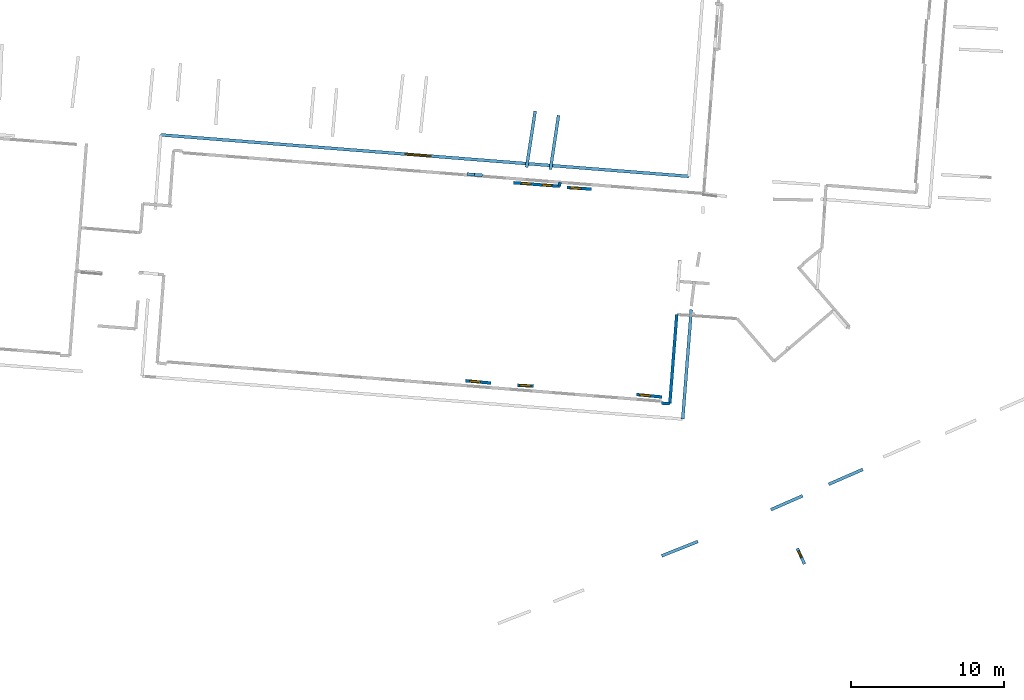
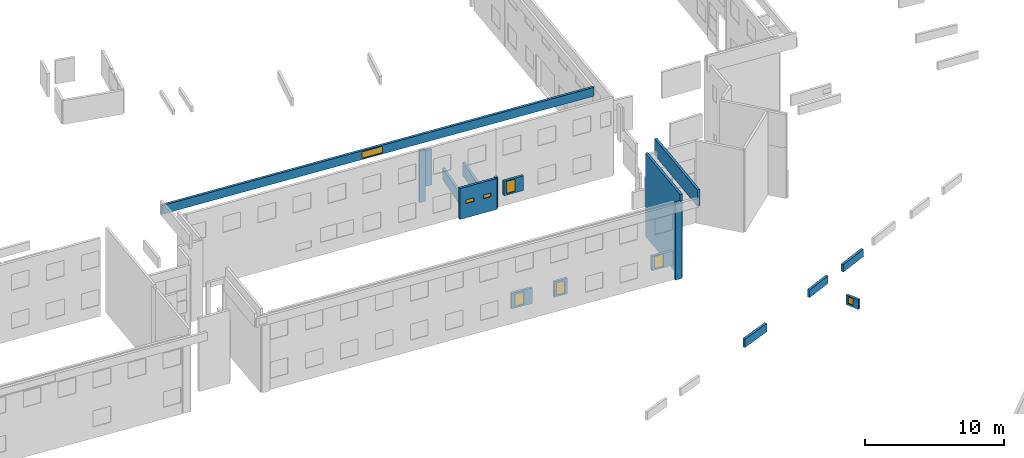
# One storey, part 19 of 27: 18 walls, 8 windows, 8 openings.
"""IFC2X3 building model written with IfcOpenShell, lengths in metres."""

from ifc_helpers import new_model, entity, si_unit, converted_unit, derived_unit, direction, frame, frame_2d, origin, origin_2d_with_axis, place, context, subcontext, project, spatial, polyline, rectangle, outline, extrude, source, transform, mapped, material, layer, layer_set, layer_usage, type_object, type_shapes, element, fill, save


model = new_model("IFC2X3")

# Units and contexts
model_context = context("Model", 3, precision=1e-05, world=origin(), true_north=direction((0.0, 1.0)))
body_context = subcontext(model_context, "Body", "Model", "MODEL_VIEW")
ifc_project = project(units=[si_unit("LENGTHUNIT", "METRE"), si_unit("AREAUNIT", "SQUARE_METRE"), si_unit("VOLUMEUNIT", "CUBIC_METRE"), converted_unit("PLANEANGLEUNIT", "DEGREE", entity("IfcRatioMeasure", 0.0174532925199433), si_unit("PLANEANGLEUNIT", "RADIAN"), dimensions=[0, 0, 0, 0, 0, 0, 0]), si_unit("MASSUNIT", "GRAM", prefix="KILO"), derived_unit("MASSDENSITYUNIT", [(si_unit("MASSUNIT", "GRAM", prefix="KILO"), 1), (si_unit("LENGTHUNIT", "METRE"), -3)]), derived_unit("MOMENTOFINERTIAUNIT", [(si_unit("LENGTHUNIT", "METRE"), 4)]), si_unit("TIMEUNIT", "SECOND"), si_unit("FREQUENCYUNIT", "HERTZ"), si_unit("THERMODYNAMICTEMPERATUREUNIT", "DEGREE_CELSIUS"), derived_unit("THERMALTRANSMITTANCEUNIT", [(si_unit("MASSUNIT", "GRAM", prefix="KILO"), 1), (si_unit("THERMODYNAMICTEMPERATUREUNIT", "KELVIN"), -1), (si_unit("TIMEUNIT", "SECOND"), -3)]), derived_unit("VOLUMETRICFLOWRATEUNIT", [(si_unit("LENGTHUNIT", "METRE"), 3), (si_unit("TIMEUNIT", "SECOND"), -1)]), si_unit("ELECTRICCURRENTUNIT", "AMPERE"), si_unit("ELECTRICVOLTAGEUNIT", "VOLT"), si_unit("POWERUNIT", "WATT"), si_unit("FORCEUNIT", "NEWTON", prefix="KILO"), si_unit("ILLUMINANCEUNIT", "LUX"), si_unit("LUMINOUSFLUXUNIT", "LUMEN"), si_unit("LUMINOUSINTENSITYUNIT", "CANDELA"), derived_unit("USERDEFINED", [(si_unit("MASSUNIT", "GRAM", prefix="KILO"), -1), (si_unit("LENGTHUNIT", "METRE"), -2), (si_unit("TIMEUNIT", "SECOND"), 3), (si_unit("LUMINOUSFLUXUNIT", "LUMEN"), 1)]), derived_unit("LINEARVELOCITYUNIT", [(si_unit("LENGTHUNIT", "METRE"), 1), (si_unit("TIMEUNIT", "SECOND"), -1)]), si_unit("PRESSUREUNIT", "PASCAL"), derived_unit("USERDEFINED", [(si_unit("LENGTHUNIT", "METRE"), -2), (si_unit("MASSUNIT", "GRAM", prefix="KILO"), 1), (si_unit("TIMEUNIT", "SECOND"), -2)]), derived_unit("LINEARFORCEUNIT", [(si_unit("MASSUNIT", "GRAM", prefix="KILO"), 1), (si_unit("LENGTHUNIT", "METRE"), 1), (si_unit("TIMEUNIT", "SECOND"), -2), (si_unit("LENGTHUNIT", "METRE"), -1)]), derived_unit("PLANARFORCEUNIT", [(si_unit("MASSUNIT", "GRAM", prefix="KILO"), 1), (si_unit("LENGTHUNIT", "METRE"), 1), (si_unit("TIMEUNIT", "SECOND"), -2), (si_unit("LENGTHUNIT", "METRE"), -2)])], contexts=[model_context])

# Site, building, storey
placement_1 = place(None, origin())
site = spatial("IfcSite", under=ifc_project, at=placement_1, CompositionType="ELEMENT")
building = spatial("IfcBuilding", under=site, at=placement_1, CompositionType="ELEMENT")
storey_placement = place(placement_1, frame((0.0, 0.0, -61.043098449707)))
storey = spatial("IfcBuildingStorey", under=building, at=storey_placement, Name="level_-61.043098", CompositionType="ELEMENT", Elevation=-61.043098449707)

# Wall
ifc_material_1 = material(Name="Default wall")
ifc_layer = layer(ifc_material_1, 0.2)
ifc_layer_set = layer_set([ifc_layer], Name="wall_thickness_0.2000")
ifc_layer_usage = layer_usage(ifc_layer_set, "AXIS2", "POSITIVE", -0.1)
wall_type = type_object("IfcWallType", Name="wall_thickness_0.2000", PredefinedType="STANDARD", material=ifc_layer_set)
placement_2 = place(placement_1, frame((0.0, 0.0, -60.9578857421875)))
wall_1_placement = place(placement_2, frame((12.4977037175095, -24.4355774544078, 0.0), z_axis=(0.0, 0.0, 1.0), x_axis=(0.916577001729123, 0.399858224751288, 0.0)))
element("IfcWallStandardCase", 1, at=wall_1_placement, inside=storey, type_object=wall_type, material=ifc_layer_usage, Name="Wall:188", ObjectType="Wall", context=body_context, shape_type="SweptSolid", body=[
    extrude(outline(polyline([(2.42807140887, -0.1), (2.42807140887, 0.1), (0.0, 0.1), (0.0, -0.1), (2.42807140887, -0.1)])), origin(), (0.0, 0.0, 1.0), 0.661750793457031),
])

# Wall, opening, window
placement_3 = place(placement_1, frame((0.0, 0.0, -59.9867630004883)))
wall_2_placement = place(placement_3, frame((-9.53913135897967, -17.8325300511373, 0.0), z_axis=(0.0, 0.0, 1.0), x_axis=(-0.995607049525731, 0.0936301390294245, 0.0)))
wall_2 = element("IfcWallStandardCase", 2, at=wall_2_placement, inside=storey, type_object=wall_type, material=ifc_layer_usage, Name="Wall:257", ObjectType="Wall", context=body_context, shape_type="SweptSolid", body=[
    extrude(outline(polyline([(1.66415564610827, -0.1), (1.66415564610827, 0.1), (0.0, 0.1), (0.0, -0.1), (1.66415564610827, -0.1)])), origin(), (0.0, 0.0, 1.0), 1.37465286254883),
])
opening_1_placement = place(wall_2_placement, frame((0.693317166831957, -0.1, 0.15277099609375)))
opening_1 = element("IfcOpeningElement", 3, at=opening_1_placement, cuts=wall_2, Name="Opening : 690 x 1070 : 15", ObjectType="Opening", context=body_context, shape_type="SweptSolid", body=[
    extrude(rectangle(XDim=0.69, YDim=1.07, at=frame_2d((0.535, 0.345), x_axis=(0.0, 1.0))), frame((0.0, 0.0, 0.0), z_axis=(0.0, 1.0, 0.0), x_axis=(0.0, 0.0, 1.0)), (0.0, 0.0, 1.0), 0.2),
])
ifc_material_2 = material(Name="Window Default")
window_style_1 = type_object("IfcWindowStyle", Name="Window : 690 x 1070mm", ConstructionType="NOTDEFINED", OperationType="NOTDEFINED", ParameterTakesPrecedence=False, Sizeable=False, material=ifc_material_2)
shared_shape_1 = source(origin(), body_context, "Body", "SweptSolid", [
    extrude(rectangle(XDim=0.1, YDim=0.69, at=origin_2d_with_axis()), frame((0.345, 0.1, 0.0), z_axis=(0.0, 0.0, 1.0), x_axis=(0.0, 1.0, 0.0)), (0.0, 0.0, 1.0), 1.07),
])
type_shapes(window_style_1, [shared_shape_1])
window_1_placement = place(opening_1_placement, origin())
window_1 = element("IfcWindow", 4, at=window_1_placement, inside=storey, type_object=window_style_1, Name="Window : 690 x 1070mm : 13", ObjectType="Window : 690 x 1070mm", OverallHeight=1.07, OverallWidth=0.69, context=body_context, shape_type="MappedRepresentation", body=[
    mapped(shared_shape_1, transform((0.0, 0.0, 0.0), scale=1.0)),
])
fill(opening_1, window_1)

placement_4 = place(placement_1, frame((0.0, 0.0, -54.4207000732422)))
wall_3_placement = place(placement_4, frame((-31.0850317500552, -1.63894712927607, 0.0), z_axis=(0.0, 0.0, 1.0), x_axis=(0.996931791597171, -0.0782751742435238, 0.0)))
wall_3 = element("IfcWallStandardCase", 5, at=wall_3_placement, inside=storey, type_object=wall_type, material=ifc_layer_usage, Name="Wall:455", ObjectType="Wall", context=body_context, shape_type="SweptSolid", body=[
    extrude(outline(polyline([(34.5646927329305, -0.1), (34.5646927329305, 0.1), (0.0, 0.1), (0.0, -0.1), (34.5646927329305, -0.1)])), origin(), (0.0, 0.0, 1.0), 0.772296905517578),
])
opening_2_placement = place(wall_3_placement, frame((16.0085291385398, -0.1, 0.0967292785644531)))
opening_2 = element("IfcOpeningElement", 6, at=opening_2_placement, cuts=wall_3, Name="Opening : 1655 x 585 : 37", ObjectType="Opening", context=body_context, shape_type="SweptSolid", body=[
    extrude(rectangle(XDim=1.655, YDim=0.585, at=frame_2d((0.2925, 0.8275), x_axis=(0.0, 1.0))), frame((0.0, 0.0, 0.0), z_axis=(0.0, 1.0, 0.0), x_axis=(0.0, 0.0, 1.0)), (0.0, 0.0, 1.0), 0.2),
])
window_style_2 = type_object("IfcWindowStyle", Name="Window : 1655 x 585mm", ConstructionType="NOTDEFINED", OperationType="NOTDEFINED", ParameterTakesPrecedence=False, Sizeable=False, material=ifc_material_2)
shared_shape_2 = source(origin(), body_context, "Body", "SweptSolid", [
    extrude(rectangle(XDim=0.1, YDim=1.655, at=origin_2d_with_axis()), frame((0.8275, 0.1, 0.0), z_axis=(0.0, 0.0, 1.0), x_axis=(0.0, 1.0, 0.0)), (0.0, 0.0, 1.0), 0.585),
])
type_shapes(window_style_2, [shared_shape_2])
window_2_placement = place(opening_2_placement, origin())
window_2 = element("IfcWindow", 7, at=window_2_placement, inside=storey, type_object=window_style_2, Name="Window : 1655 x 585mm : 32", ObjectType="Window : 1655 x 585mm", OverallHeight=0.585, OverallWidth=1.655, context=body_context, shape_type="MappedRepresentation", body=[
    mapped(shared_shape_2, transform((0.0, 0.0, 0.0), scale=1.0)),
])
fill(opening_2, window_2)

# Walls
wall_4_placement = place(storey_placement, frame((-5.03805124397359, -4.72673401802016, 0.0), z_axis=(0.0, 0.0, 1.0), x_axis=(-0.129665213204993, -0.991557831134676, 0.0)))
element("IfcWallStandardCase", 8, at=wall_4_placement, inside=storey, type_object=wall_type, material=ifc_layer_usage, Name="Wall:480", ObjectType="Wall", context=body_context, shape_type="SweptSolid", body=[
    extrude(outline(polyline([(0.264290876779452, -0.1), (0.264290876779452, 0.1), (0.0, 0.1), (0.0, -0.1), (0.264290876779452, -0.1)])), origin(), (0.0, 0.0, 1.0), 2.72571182250977),
])
wall_5_placement = place(storey_placement, frame((2.58508048580188, -13.3566288035717, 0.0), z_axis=(0.0, 0.0, 1.0), x_axis=(-0.0778159706804258, -0.996967740053339, 0.0)))
element("IfcWallStandardCase", 9, at=wall_5_placement, inside=storey, type_object=wall_type, material=ifc_layer_usage, Name="Wall:677", ObjectType="Wall", context=body_context, shape_type="SweptSolid", body=[
    extrude(outline(polyline([(5.83412161884098, -0.1), (5.83412161884098, 0.1), (0.0, 0.1), (0.0, -0.1), (5.83412161884098, -0.1)])), origin(), (0.0, 0.0, 1.0), 7.32660675048828),
])
placement_5 = place(placement_1, frame((0.0, 0.0, -60.8847198486328)))
wall_6_placement = place(placement_5, frame((-5.65662918235476, -3.8956626353485, 0.0), z_axis=(0.0, 0.0, 1.0), x_axis=(0.147887768183979, 0.989004149648302, 0.0)))
element("IfcWallStandardCase", 10, at=wall_6_placement, inside=storey, type_object=wall_type, material=ifc_layer_usage, Name="Wall:711", ObjectType="Wall", context=body_context, shape_type="SweptSolid", body=[
    extrude(outline(polyline([(3.57000009706302, -0.1), (3.57000009706302, 0.1), (0.0, 0.1), (0.0, -0.1), (3.57000009706302, -0.1)])), origin(), (0.0, 0.0, 1.0), 1.1801872253418),
])

# Wall, opening, window
placement_6 = place(placement_1, frame((0.0, 0.0, -59.9867630004883)))
wall_7_placement = place(placement_6, frame((-7.81663886912711, -17.970377953164, 0.0), z_axis=(0.0, 0.0, 1.0), x_axis=(0.998124807269346, -0.0612116746505977, 0.0)))
wall_7 = element("IfcWallStandardCase", 11, at=wall_7_placement, inside=storey, type_object=wall_type, material=ifc_layer_usage, Name="Wall:952", ObjectType="Wall", context=body_context, shape_type="SweptSolid", body=[
    extrude(outline(polyline([(1.06900211306765, -0.1), (1.06900211306765, 0.1), (0.0, 0.1), (0.0, -0.1), (1.06900211306765, -0.1)])), origin(), (0.0, 0.0, 1.0), 1.37465286254883),
])
opening_3_placement = place(wall_7_placement, frame((0.164999801310482, -0.1, 0.145214080810547)))
opening_3 = element("IfcOpeningElement", 12, at=opening_3_placement, cuts=wall_7, Name="Opening : 700 x 1070 : 110", ObjectType="Opening", context=body_context, shape_type="SweptSolid", body=[
    extrude(rectangle(XDim=0.7, YDim=1.07, at=frame_2d((0.535, 0.35), x_axis=(0.0, 1.0))), frame((0.0, 0.0, 0.0), z_axis=(0.0, 1.0, 0.0), x_axis=(0.0, 0.0, 1.0)), (0.0, 0.0, 1.0), 0.2),
])
window_style_3 = type_object("IfcWindowStyle", Name="Window : 700 x 1070mm", ConstructionType="NOTDEFINED", OperationType="NOTDEFINED", ParameterTakesPrecedence=False, Sizeable=False, material=ifc_material_2)
shared_shape_3 = source(origin(), body_context, "Body", "SweptSolid", [
    extrude(rectangle(XDim=0.1, YDim=0.7, at=origin_2d_with_axis()), frame((0.35, 0.1, 0.0), z_axis=(0.0, 0.0, 1.0), x_axis=(0.0, 1.0, 0.0)), (0.0, 0.0, 1.0), 1.07),
])
type_shapes(window_style_3, [shared_shape_3])
window_3_placement = place(opening_3_placement, origin())
window_3 = element("IfcWindow", 13, at=window_3_placement, inside=storey, type_object=window_style_3, Name="Window : 700 x 1070mm : 98", ObjectType="Window : 700 x 1070mm", OverallHeight=1.07, OverallWidth=0.7, context=body_context, shape_type="MappedRepresentation", body=[
    mapped(shared_shape_3, transform((0.0, 0.0, 0.0), scale=1.0)),
])
fill(opening_3, window_3)

# Wall
placement_7 = place(placement_1, frame((0.0, 0.0, -60.8847198486328)))
wall_8_placement = place(placement_7, frame((-7.21205877372114, -3.75820354474582, 0.0), z_axis=(0.0, 0.0, 1.0), x_axis=(0.150626064042175, 0.988590809602822, 0.0)))
element("IfcWallStandardCase", 14, at=wall_8_placement, inside=storey, type_object=wall_type, material=ifc_layer_usage, Name="Wall:1071", ObjectType="Wall", context=body_context, shape_type="SweptSolid", body=[
    extrude(outline(polyline([(3.72000001448494, -0.1), (3.72000001448494, 0.1), (0.0, 0.1), (0.0, -0.1), (3.72000001448494, -0.1)])), origin(), (0.0, 0.0, 1.0), 1.01820373535156),
])

# Wall, opening, window
placement_8 = place(placement_1, frame((0.0, 0.0, -59.9867630004883)))
wall_9_placement = place(placement_8, frame((1.6137878881182, -18.7391027157031, 0.0), z_axis=(0.0, 0.0, 1.0), x_axis=(-0.99539400204523, 0.0958685594571029, 0.0)))
wall_9 = element("IfcWallStandardCase", 15, at=wall_9_placement, inside=storey, type_object=wall_type, material=ifc_layer_usage, Name="Wall:1177", ObjectType="Wall", context=body_context, shape_type="SweptSolid", body=[
    extrude(outline(polyline([(1.65842546175415, -0.1), (1.65842546175415, 0.1), (0.0, 0.1), (0.0, -0.1), (1.65842546175415, -0.1)])), origin(), (0.0, 0.0, 1.0), 1.27852630615234),
])
opening_4_placement = place(wall_9_placement, frame((0.750615696213164, -0.1, 0.132789611816406)))
opening_4 = element("IfcOpeningElement", 16, at=opening_4_placement, cuts=wall_9, Name="Opening : 695 x 1075 : 164", ObjectType="Opening", context=body_context, shape_type="SweptSolid", body=[
    extrude(rectangle(XDim=0.695, YDim=1.075, at=frame_2d((0.5375, 0.3475), x_axis=(0.0, 1.0))), frame((0.0, 0.0, 0.0), z_axis=(0.0, 1.0, 0.0), x_axis=(0.0, 0.0, 1.0)), (0.0, 0.0, 1.0), 0.2),
])
window_style_4 = type_object("IfcWindowStyle", Name="Window : 695 x 1075mm", ConstructionType="NOTDEFINED", OperationType="NOTDEFINED", ParameterTakesPrecedence=False, Sizeable=False, material=ifc_material_2)
shared_shape_4 = source(origin(), body_context, "Body", "SweptSolid", [
    extrude(rectangle(XDim=0.1, YDim=0.695, at=origin_2d_with_axis()), frame((0.3475, 0.1, 0.0), z_axis=(0.0, 0.0, 1.0), x_axis=(0.0, 1.0, 0.0)), (0.0, 0.0, 1.0), 1.075),
])
type_shapes(window_style_4, [shared_shape_4])
window_4_placement = place(opening_4_placement, origin())
window_4 = element("IfcWindow", 17, at=window_4_placement, inside=storey, type_object=window_style_4, Name="Window : 695 x 1075mm : 149", ObjectType="Window : 695 x 1075mm", OverallHeight=1.075, OverallWidth=0.695, context=body_context, shape_type="MappedRepresentation", body=[
    mapped(shared_shape_4, transform((0.0, 0.0, 0.0), scale=1.0)),
])
fill(opening_4, window_4)

# Walls
placement_9 = place(placement_1, frame((0.0, 0.0, -60.8847198486328)))
wall_10_placement = place(placement_9, frame((8.72074236151945, -26.0940565617844, 0.0), z_axis=(0.0, 0.0, 1.0), x_axis=(0.916189457370173, 0.40074540322223, 0.0)))
element("IfcWallStandardCase", 18, at=wall_10_placement, inside=storey, type_object=wall_type, material=ifc_layer_usage, Name="Wall:1522", ObjectType="Wall", context=body_context, shape_type="SweptSolid", body=[
    extrude(outline(polyline([(2.26469965870573, -0.1), (2.26469965870573, 0.1), (0.0, 0.1), (0.0, -0.1), (2.26469965870573, -0.1)])), origin(), (0.0, 0.0, 1.0), 0.666728973388672),
])
placement_10 = place(placement_1, frame((0.0, 0.0, -60.9578857421875)))
wall_11_placement = place(placement_10, frame((1.59733462857245, -29.1065291744062, 0.0), z_axis=(0.0, 0.0, 1.0), x_axis=(0.929661318041133, 0.368415300629634, 0.0)))
element("IfcWallStandardCase", 19, at=wall_11_placement, inside=storey, type_object=wall_type, material=ifc_layer_usage, Name="Wall:1611", ObjectType="Wall", context=body_context, shape_type="SweptSolid", body=[
    extrude(outline(polyline([(2.54288610821355, -0.1), (2.54288610821355, 0.1), (0.0, 0.1), (0.0, -0.1), (2.54288610821355, -0.1)])), origin(), (0.0, 0.0, 1.0), 0.739894866943359),
])

# Wall, openings, windows
wall_12_placement = place(storey_placement, frame((-5.07232000501293, -4.98879334553879, 0.0), z_axis=(0.0, 0.0, 1.0), x_axis=(-0.997094837058065, 0.0761701116721751, 0.0)))
wall_12 = element("IfcWallStandardCase", 20, at=wall_12_placement, inside=storey, type_object=wall_type, material=ifc_layer_usage, Name="Wall:1614", ObjectType="Wall", context=body_context, shape_type="SweptSolid", body=[
    extrude(outline(polyline([(2.99449164619464, -0.1), (2.99449164619464, 0.1), (0.0, 0.1), (0.0, -0.1), (2.99449164619464, -0.1)])), origin(), (0.0, 0.0, 1.0), 2.72571182250977),
])
opening_5_placement = place(wall_12_placement, frame((0.511039999586011, -0.1, 1.2650260925293)))
opening_5 = element("IfcOpeningElement", 21, at=opening_5_placement, cuts=wall_12, Name="Opening : 605 x 320 : 266", ObjectType="Opening", context=body_context, shape_type="SweptSolid", body=[
    extrude(rectangle(XDim=0.605, YDim=0.32, at=frame_2d((0.16, 0.3025), x_axis=(0.0, 1.0))), frame((0.0, 0.0, 0.0), z_axis=(0.0, 1.0, 0.0), x_axis=(0.0, 0.0, 1.0)), (0.0, 0.0, 1.0), 0.2),
])
opening_6_placement = place(wall_12_placement, frame((1.87603992187826, -0.1, 1.2650260925293)))
opening_6 = element("IfcOpeningElement", 22, at=opening_6_placement, cuts=wall_12, Name="Opening : 605 x 315 : 267", ObjectType="Opening", context=body_context, shape_type="SweptSolid", body=[
    extrude(rectangle(XDim=0.605, YDim=0.315, at=frame_2d((0.1575, 0.3025), x_axis=(0.0, 1.0))), frame((0.0, 0.0, 0.0), z_axis=(0.0, 1.0, 0.0), x_axis=(0.0, 0.0, 1.0)), (0.0, 0.0, 1.0), 0.2),
])
window_style_5 = type_object("IfcWindowStyle", Name="Window : 605 x 320mm", ConstructionType="NOTDEFINED", OperationType="NOTDEFINED", ParameterTakesPrecedence=False, Sizeable=False, material=ifc_material_2)
shared_shape_5 = source(origin(), body_context, "Body", "SweptSolid", [
    extrude(rectangle(XDim=0.1, YDim=0.605, at=origin_2d_with_axis()), frame((0.3025, 0.1, 0.0), z_axis=(0.0, 0.0, 1.0), x_axis=(0.0, 1.0, 0.0)), (0.0, 0.0, 1.0), 0.32),
])
type_shapes(window_style_5, [shared_shape_5])
window_5_placement = place(opening_5_placement, origin())
window_5 = element("IfcWindow", 23, at=window_5_placement, inside=storey, type_object=window_style_5, Name="Window : 605 x 320mm : 249", ObjectType="Window : 605 x 320mm", OverallHeight=0.32, OverallWidth=0.605, context=body_context, shape_type="MappedRepresentation", body=[
    mapped(shared_shape_5, transform((0.0, 0.0, 0.0), scale=1.0)),
])
fill(opening_5, window_5)
window_style_6 = type_object("IfcWindowStyle", Name="Window : 605 x 315mm", ConstructionType="NOTDEFINED", OperationType="NOTDEFINED", ParameterTakesPrecedence=False, Sizeable=False, material=ifc_material_2)
shared_shape_6 = source(origin(), body_context, "Body", "SweptSolid", [
    extrude(rectangle(XDim=0.1, YDim=0.605, at=origin_2d_with_axis()), frame((0.3025, 0.1, 0.0), z_axis=(0.0, 0.0, 1.0), x_axis=(0.0, 1.0, 0.0)), (0.0, 0.0, 1.0), 0.315),
])
type_shapes(window_style_6, [shared_shape_6])
window_6_placement = place(opening_6_placement, origin())
window_6 = element("IfcWindow", 24, at=window_6_placement, inside=storey, type_object=window_style_6, Name="Window : 605 x 315mm : 250", ObjectType="Window : 605 x 315mm", OverallHeight=0.315, OverallWidth=0.605, context=body_context, shape_type="MappedRepresentation", body=[
    mapped(shared_shape_6, transform((0.0, 0.0, 0.0), scale=1.0)),
])
fill(opening_6, window_6)

# Walls
placement_11 = place(placement_1, frame((0.0, 0.0, -57.5610122680664)))
wall_13_placement = place(placement_11, frame((-10.6078675185355, -4.23839703435485, 0.0), z_axis=(0.0, 0.0, 1.0), x_axis=(0.997099159204708, -0.076113512028179, 0.0)))
element("IfcWallStandardCase", 25, at=wall_13_placement, inside=storey, type_object=wall_type, material=ifc_layer_usage, Name="Wall:1645", ObjectType="Wall", context=body_context, shape_type="SweptSolid", body=[
    extrude(outline(polyline([(0.506203408478989, -0.1), (0.506203408478989, 0.1), (0.0, 0.1), (0.0, -0.1), (0.506203408478989, -0.1)])), origin(), (0.0, 0.0, 1.0), 3.1456298828125),
])
placement_12 = place(placement_1, frame((0.0, 0.0, -58.8460121154785)))
wall_14_placement = place(placement_12, frame((-11.0964453612479, -4.20110026235168, 0.0), z_axis=(0.0, 0.0, 1.0), x_axis=(0.99709902948419, -0.0761152113685973, 0.0)))
element("IfcWallStandardCase", 26, at=wall_14_placement, inside=storey, type_object=wall_type, material=ifc_layer_usage, Name="Wall:1646", ObjectType="Wall", context=body_context, shape_type="SweptSolid", body=[
    extrude(outline(polyline([(0.475000283901118, -0.1), (0.475000283901118, 0.1), (0.0, 0.1), (0.0, -0.1), (0.475000283901118, -0.1)])), origin(), (0.0, 0.0, 1.0), 4.56510543823242),
])

# Wall, opening, window
placement_13 = place(placement_1, frame((0.0, 0.0, -60.5363845825195)))
wall_15_placement = place(placement_13, frame((10.4456484811266, -28.615589608971, 0.0), z_axis=(0.0, 0.0, 1.0), x_axis=(0.420269880335465, -0.907399155654673, 0.0)))
wall_15 = element("IfcWallStandardCase", 27, at=wall_15_placement, inside=storey, type_object=wall_type, material=ifc_layer_usage, Name="Wall:1904", ObjectType="Wall", context=body_context, shape_type="SweptSolid", body=[
    extrude(outline(polyline([(1.11999977478748, -0.1), (1.11999977478748, 0.1), (0.0, 0.1), (0.0, -0.1), (1.11999977478748, -0.1)])), origin(), (0.0, 0.0, 1.0), 0.831851959228516),
])
opening_7_placement = place(wall_15_placement, frame((0.18433643100438, -0.1, 0.173927307128906)))
opening_7 = element("IfcOpeningElement", 28, at=opening_7_placement, cuts=wall_15, Name="Opening : 465 x 580 : 291", ObjectType="Opening", context=body_context, shape_type="SweptSolid", body=[
    extrude(rectangle(XDim=0.465, YDim=0.58, at=frame_2d((0.29, 0.2325), x_axis=(0.0, 1.0))), frame((0.0, 0.0, 0.0), z_axis=(0.0, 1.0, 0.0), x_axis=(0.0, 0.0, 1.0)), (0.0, 0.0, 1.0), 0.2),
])
window_style_7 = type_object("IfcWindowStyle", Name="Window : 465 x 580mm", ConstructionType="NOTDEFINED", OperationType="NOTDEFINED", ParameterTakesPrecedence=False, Sizeable=False, material=ifc_material_2)
shared_shape_7 = source(origin(), body_context, "Body", "SweptSolid", [
    extrude(rectangle(XDim=0.1, YDim=0.465, at=origin_2d_with_axis()), frame((0.2325, 0.1, 0.0), z_axis=(0.0, 0.0, 1.0), x_axis=(0.0, 1.0, 0.0)), (0.0, 0.0, 1.0), 0.58),
])
type_shapes(window_style_7, [shared_shape_7])
window_7_placement = place(opening_7_placement, origin())
window_7 = element("IfcWindow", 29, at=window_7_placement, inside=storey, type_object=window_style_7, Name="Window : 465 x 580mm : 272", ObjectType="Window : 465 x 580mm", OverallHeight=0.58, OverallWidth=0.465, context=body_context, shape_type="MappedRepresentation", body=[
    mapped(shared_shape_7, transform((0.0, 0.0, 0.0), scale=1.0)),
])
fill(opening_7, window_7)

# Walls
wall_16_placement = place(storey_placement, frame((2.13109308192246, -19.1730590684795, 0.0), z_axis=(0.0, 0.0, 1.0), x_axis=(-0.998462853881201, 0.0554249891241128, 0.0)))
element("IfcWallStandardCase", 30, at=wall_16_placement, inside=storey, type_object=wall_type, material=ifc_layer_usage, Name="Wall:1942", ObjectType="Wall", context=body_context, shape_type="SweptSolid", body=[
    extrude(outline(polyline([(0.547478851668603, -0.1), (0.547478851668603, 0.1), (0.0, 0.1), (0.0, -0.1), (0.547478851668603, -0.1)])), origin(), (0.0, 0.0, 1.0), 6.76219177246094),
])
placement_14 = place(placement_1, frame((0.0, 0.0, -54.4207000732422)))
wall_17_placement = place(placement_14, frame((2.97322435888041, -20.1827873251651, 0.0), z_axis=(0.0, 0.0, 1.0), x_axis=(0.0780525370111325, 0.996949247186699, 0.0)))
element("IfcWallStandardCase", 31, at=wall_17_placement, inside=storey, type_object=wall_type, material=ifc_layer_usage, Name="Wall:1948", ObjectType="Wall", context=body_context, shape_type="SweptSolid", body=[
    extrude(outline(polyline([(7.16019351358641, -0.1), (7.16019351358641, 0.1), (0.0, 0.1), (0.0, -0.1), (7.16019351358641, -0.1)])), origin(), (0.0, 0.0, 1.0), 1.45384979248047),
])

# Wall, opening, window
placement_15 = place(placement_1, frame((0.0, 0.0, -59.9867630004883)))
wall_18_placement = place(placement_15, frame((-2.98399298061695, -5.17623488623806, 0.0), z_axis=(0.0, 0.0, 1.0), x_axis=(-0.99804087841908, 0.0625652060211735, 0.0)))
wall_18 = element("IfcWallStandardCase", 32, at=wall_18_placement, inside=storey, type_object=wall_type, material=ifc_layer_usage, Name="Wall:1954", ObjectType="Wall", context=body_context, shape_type="SweptSolid", body=[
    extrude(outline(polyline([(1.5859537176952, -0.1), (1.5859537176952, 0.1), (0.0, 0.1), (0.0, -0.1), (1.5859537176952, -0.1)])), origin(), (0.0, 0.0, 1.0), 1.27852630615234),
])
opening_8_placement = place(wall_18_placement, frame((0.683739779840213, -0.1, 0.131237030029297)))
opening_8 = element("IfcOpeningElement", 33, at=opening_8_placement, cuts=wall_18, Name="Opening : 695 x 1075 : 292", ObjectType="Opening", context=body_context, shape_type="SweptSolid", body=[
    extrude(rectangle(XDim=0.695, YDim=1.075, at=frame_2d((0.5375, 0.3475), x_axis=(0.0, 1.0))), frame((0.0, 0.0, 0.0), z_axis=(0.0, 1.0, 0.0), x_axis=(0.0, 0.0, 1.0)), (0.0, 0.0, 1.0), 0.2),
])
window_8_placement = place(opening_8_placement, origin())
window_8 = element("IfcWindow", 34, at=window_8_placement, inside=storey, type_object=window_style_4, Name="Window : 695 x 1075mm : 273", ObjectType="Window : 695 x 1075mm", OverallHeight=1.075, OverallWidth=0.695, context=body_context, shape_type="MappedRepresentation", body=[
    mapped(shared_shape_4, transform((0.0, 0.0, 0.0), scale=1.0)),
])
fill(opening_8, window_8)

save(model, "model.ifc")
